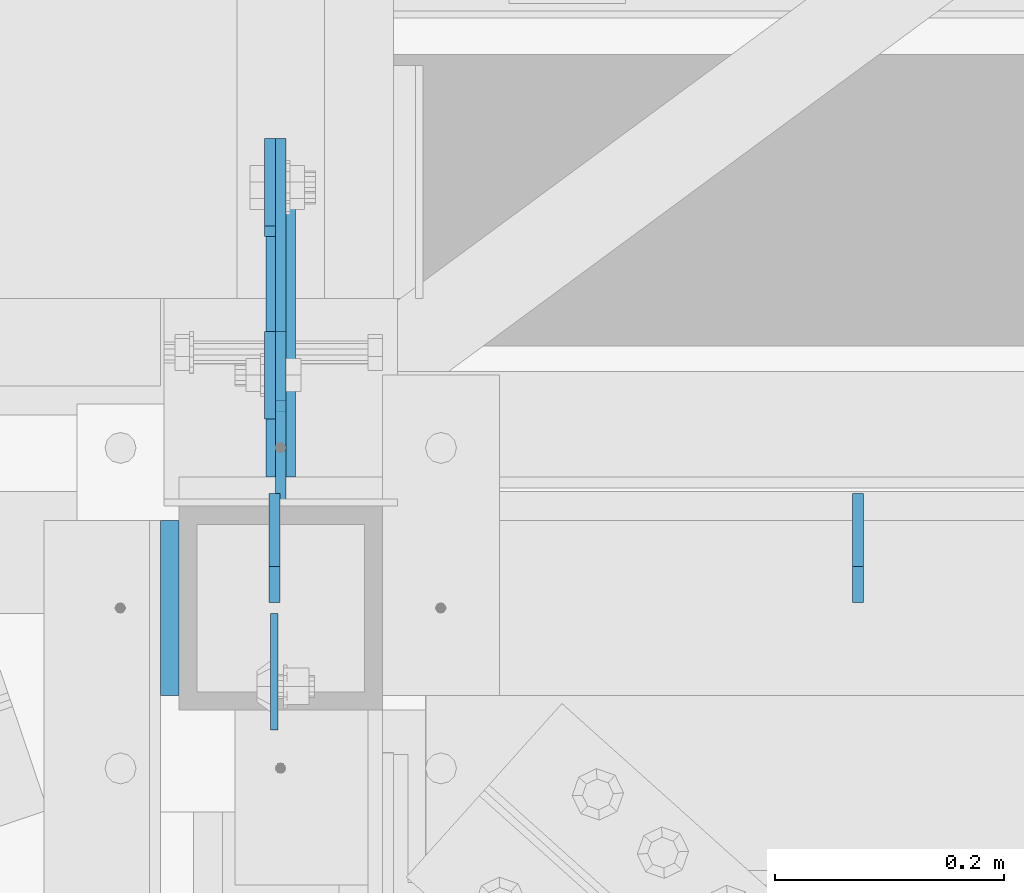
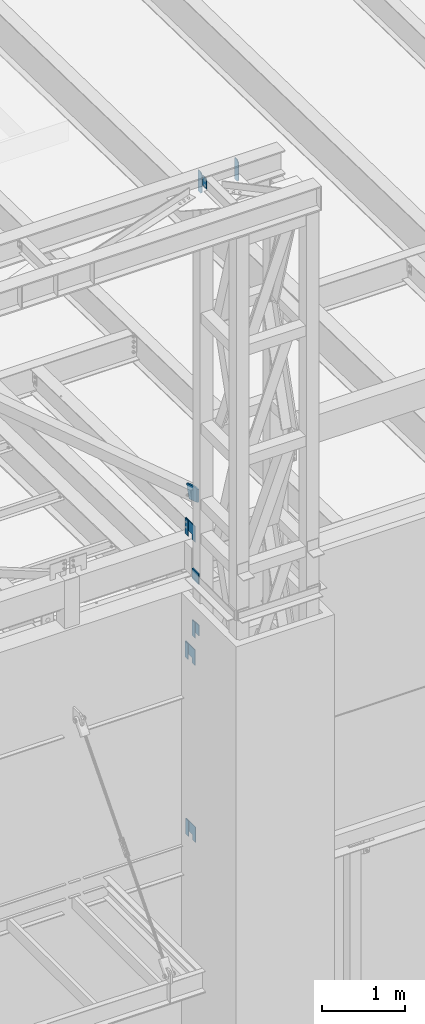
# One storey, part 1480 of 1763: 13 plates, 6 elements without a shape of their own.
"""IFC2X3 building model written with IfcOpenShell, lengths in millimetres."""

from ifc_helpers import new_model, si_unit, frame, origin_with_axes, place, context, subcontext, project, spatial, faceted_brep, material, type_object, element, aggregate, save


model = new_model("IFC2X3")

# Units and contexts
model_context = context("Model", 3, precision=1e-05, world=origin_with_axes())
body_context = subcontext(model_context, "Body", "Model", "MODEL_VIEW")
ifc_project = project(units=[si_unit("LENGTHUNIT", "METRE", prefix="MILLI"), si_unit("AREAUNIT", "SQUARE_METRE"), si_unit("VOLUMEUNIT", "CUBIC_METRE"), si_unit("MASSUNIT", "GRAM", prefix="KILO"), si_unit("TIMEUNIT", "SECOND"), si_unit("PLANEANGLEUNIT", "RADIAN"), si_unit("SOLIDANGLEUNIT", "STERADIAN"), si_unit("THERMODYNAMICTEMPERATUREUNIT", "DEGREE_CELSIUS"), si_unit("LUMINOUSINTENSITYUNIT", "LUMEN")], contexts=[model_context])

# Site, building, storey
site_placement = place(None, origin_with_axes())
site = spatial("IfcSite", under=ifc_project, at=site_placement, CompositionType="ELEMENT")
building_placement = place(site_placement, origin_with_axes())
building = spatial("IfcBuilding", under=site, at=building_placement, Name="Undefined", CompositionType="ELEMENT")
storey_placement = place(building_placement, origin_with_axes())
storey = spatial("IfcBuildingStorey", under=building, at=storey_placement, Name="Undefined", CompositionType="ELEMENT", Elevation=0.0)

# Assembly, plate
assembly_1_placement = place(storey_placement, origin_with_axes())
assembly_1 = element("IfcElementAssembly", 1, at=assembly_1_placement, inside=storey, Name="BEAM", AssemblyPlace="NOTDEFINED", PredefinedType="RIGID_FRAME")
ifc_material = material(Name="STEEL/A36")
plate_type_1 = type_object("IfcPlateType", PredefinedType="NOTDEFINED")
plate_1_placement = place(assembly_1_placement, frame((-47745.0773941528, -14179.5521887748, 8839.2), z_axis=(0.0, 0.0, 1.0), x_axis=(0.0, -1.0, 0.0)))
plate_1 = element("IfcPlate", 2, at=plate_1_placement, type_object=plate_type_1, material=ifc_material, Name="PLATE", context=body_context, shape_type="Brep", body=[
    faceted_brep([(0.0, -4.76249999999982, 0.0), (-2.83762346953154e-10, -4.7624999996915, 228.600006103516), (-2.83762346953154e-10, 4.76250000028813, 228.600006103517), (0.0, 4.76249999999982, 0.0), (76.1999969480166, -4.76249999961874, 228.600006103516), (76.1999969480166, 4.76250000036089, 228.600006103517), (76.1999969482931, -4.76249999991705, 0.0), (76.1999969482931, 4.76250000006257, 1.81898940354586e-12)], [[[0, 1, 2, 3]], [[1, 4, 5, 2]], [[4, 6, 7, 5]], [[6, 0, 3, 7]], [[5, 7, 3, 2]], [[6, 4, 1, 0]]]),
])
aggregate(assembly_1, [plate_1])

assembly_2_placement = place(storey_placement, origin_with_axes())
assembly_2 = element("IfcElementAssembly", 3, at=assembly_2_placement, inside=storey, Name="BEAM", AssemblyPlace="NOTDEFINED", PredefinedType="RIGID_FRAME")
plate_2_placement = place(assembly_2_placement, frame((-47745.0774000216, -14170.027189118, 11442.7), z_axis=(0.0, 0.0, 1.0), x_axis=(0.0, -1.0, 0.0)))
plate_2 = element("IfcPlate", 4, at=plate_2_placement, type_object=plate_type_1, material=ifc_material, Name="PLATE", context=body_context, shape_type="Brep", body=[
    faceted_brep([(0.0, -4.76249999999982, 0.0), (-2.83762346953154e-10, -4.7624999996915, 228.600006103516), (-2.83762346953154e-10, 4.76250000028813, 228.600006103517), (0.0, 4.76249999999982, 0.0), (76.1999969480166, -4.76249999961874, 228.600006103516), (76.1999969480166, 4.76250000036089, 228.600006103517), (76.1999969482931, -4.76249999991705, 0.0), (76.1999969482931, 4.76250000006257, 1.81898940354586e-12)], [[[0, 1, 2, 3]], [[1, 4, 5, 2]], [[4, 6, 7, 5]], [[6, 0, 3, 7]], [[5, 7, 3, 2]], [[6, 4, 1, 0]]]),
])
aggregate(assembly_2, [plate_2])

assembly_3_placement = place(storey_placement, origin_with_axes())
assembly_3 = element("IfcElementAssembly", 5, at=assembly_3_placement, inside=storey, Name="BEAM", AssemblyPlace="NOTDEFINED", PredefinedType="RIGID_FRAME")
plate_3_placement = place(assembly_3_placement, frame((-47745.0774016422, -14414.5021973342, 11858.625), z_axis=(0.0, 0.0, 1.0), x_axis=(0.0, 1.0, 0.0)))
plate_3 = element("IfcPlate", 6, at=plate_3_placement, type_object=plate_type_1, material=ifc_material, Name="PLATE", context=body_context, shape_type="Brep", body=[
    faceted_brep([(0.0, -4.76249999999982, 0.0), (-2.83762346953154e-10, -4.7624999996915, 228.600006103516), (-2.83762346953154e-10, 4.76250000028813, 228.600006103517), (0.0, 4.76249999999982, 0.0), (76.1999969480166, -4.76249999961874, 228.600006103516), (76.1999969480166, 4.76250000036089, 228.600006103517), (76.1999969482931, -4.76249999991705, 0.0), (76.1999969482931, 4.76250000006257, 1.81898940354586e-12)], [[[0, 1, 2, 3]], [[1, 4, 5, 2]], [[4, 6, 7, 5]], [[6, 0, 3, 7]], [[5, 7, 3, 2]], [[6, 4, 1, 0]]]),
])
aggregate(assembly_3, [plate_3])

assembly_4_placement = place(storey_placement, origin_with_axes())
assembly_4 = element("IfcElementAssembly", 7, at=assembly_4_placement, inside=storey, Name="BEAM", AssemblyPlace="NOTDEFINED", PredefinedType="RIGID_FRAME")
plate_4_placement = place(assembly_4_placement, frame((-47745.0774018501, -14170.0271890037, 13258.8221257957), z_axis=(0.0, 0.0, 1.0), x_axis=(0.0, -1.0, 0.0)))
plate_4 = element("IfcPlate", 8, at=plate_4_placement, type_object=plate_type_1, material=ifc_material, Name="PLATE", context=body_context, shape_type="Brep", body=[
    faceted_brep([(0.0, -4.76249999999982, 0.0), (-2.83762346953154e-10, -4.7624999996915, 228.600006103516), (-2.83762346953154e-10, 4.76250000028813, 228.600006103517), (0.0, 4.76249999999982, 0.0), (76.1999969480166, -4.76249999961874, 228.600006103516), (76.1999969480166, 4.76250000036089, 228.600006103517), (76.1999969482931, -4.76249999991705, 0.0), (76.1999969482931, 4.76250000006257, 1.81898940354586e-12)], [[[0, 1, 2, 3]], [[1, 4, 5, 2]], [[4, 6, 7, 5]], [[6, 0, 3, 7]], [[5, 7, 3, 2]], [[6, 4, 1, 0]]]),
])
aggregate(assembly_4, [plate_4])

# Assembly, plates
assembly_5_placement = place(storey_placement, origin_with_axes())
assembly_5 = element("IfcElementAssembly", 9, at=assembly_5_placement, inside=storey, Name="FRAME", AssemblyPlace="NOTDEFINED", PredefinedType="RIGID_FRAME")
plate_type_2 = type_object("IfcPlateType", PredefinedType="NOTDEFINED")
plate_5_placement = place(assembly_5_placement, frame((-47735.5523971252, -14408.1595639567, 9067.75577032242), z_axis=(-4.00000135414302e-09, 9.67160000327568e-05, -0.999999995323008), x_axis=(-1.2000009728941e-08, 0.999999995323008, 9.67160000319667e-05)))
plate_5 = element("IfcPlate", 10, at=plate_5_placement, type_object=plate_type_2, material=ifc_material, Name="PLATE", context=body_context, shape_type="Brep", body=[
    faceted_brep([(0.0, -4.76249999999982, 0.0), (-0.0147415312894736, -4.76250000055734, 228.577880859459), (-0.0147415312967496, 4.76249999946594, 228.577880859457), (0.0, 4.76249999999982, 0.0), (76.1926269535688, -4.76250000031723, 228.563140869262), (76.1926269535616, 4.76249999970605, 228.563140869261), (76.1999969485987, -4.76250000013533, 152.385253906345), (76.1999969485914, 4.76249999988795, 152.385253906343), (228.59263610909, -4.76249999964057, 152.399993896655), (228.592636109082, 4.76250000037544, 152.399993896655), (228.607376099128, -4.76249999928405, 2.14640749618411e-10), (228.607376099135, 4.76250000073924, 2.12821760214865e-10)], [[[0, 1, 2, 3]], [[1, 4, 5, 2]], [[4, 6, 7, 5]], [[6, 8, 9, 7]], [[8, 10, 11, 9]], [[10, 0, 3, 11]], [[5, 7, 9, 11, 3, 2]], [[10, 8, 6, 4, 1, 0]]]),
])
plate_6_placement = place(assembly_5_placement, frame((-47735.5523971252, -14398.6345639567, 11671.2557703224), z_axis=(-4.00000135414302e-09, 9.67160000327568e-05, -0.999999995323008), x_axis=(-1.2000009728941e-08, 0.999999995323008, 9.67160000319667e-05)))
plate_6 = element("IfcPlate", 11, at=plate_6_placement, type_object=plate_type_2, material=ifc_material, Name="PLATE", context=body_context, shape_type="Brep", body=[
    faceted_brep([(0.0, -4.76249999999982, 0.0), (-0.0147415312894736, -4.76250000055734, 228.577880859459), (-0.0147415312967496, 4.76249999946594, 228.577880859457), (0.0, 4.76249999999982, 0.0), (76.1926269535688, -4.76250000031723, 228.563140869262), (76.1926269535616, 4.76249999970605, 228.563140869261), (76.1999969485987, -4.76250000013533, 152.385253906345), (76.1999969485914, 4.76249999988795, 152.385253906343), (228.59263610909, -4.76249999964057, 152.399993896655), (228.592636109082, 4.76250000037544, 152.399993896655), (228.607376099128, -4.76249999928405, 2.14640749618411e-10), (228.607376099135, 4.76250000073924, 2.12821760214865e-10)], [[[0, 1, 2, 3]], [[1, 4, 5, 2]], [[4, 6, 7, 5]], [[6, 8, 9, 7]], [[8, 10, 11, 9]], [[10, 0, 3, 11]], [[5, 7, 9, 11, 3, 2]], [[10, 8, 6, 4, 1, 0]]]),
])
plate_7_placement = place(assembly_5_placement, frame((-47735.5523993351, -14398.6345639567, 13487.3778961182), z_axis=(-4.00000135414302e-09, 9.67160000327568e-05, -0.999999995323008), x_axis=(-1.2000009728941e-08, 0.999999995323008, 9.67160000319667e-05)))
plate_7 = element("IfcPlate", 12, at=plate_7_placement, type_object=plate_type_2, material=ifc_material, Name="PLATE", context=body_context, shape_type="Brep", body=[
    faceted_brep([(0.0, -4.76249999999982, 0.0), (-0.0147415312894736, -4.76250000055734, 228.577880859459), (-0.0147415312967496, 4.76249999946594, 228.577880859457), (0.0, 4.76249999999982, 0.0), (76.1926269535688, -4.76250000031723, 228.563140869262), (76.1926269535616, 4.76249999970605, 228.563140869261), (76.1999969485987, -4.76250000013533, 152.385253906345), (76.1999969485914, 4.76249999988795, 152.385253906343), (228.59263610909, -4.76249999964057, 152.399993896655), (228.592636109082, 4.76250000037544, 152.399993896655), (228.607376099128, -4.76249999928405, 2.14640749618411e-10), (228.607376099135, 4.76250000073924, 2.12821760214865e-10)], [[[0, 1, 2, 3]], [[1, 4, 5, 2]], [[4, 6, 7, 5]], [[6, 8, 9, 7]], [[8, 10, 11, 9]], [[10, 0, 3, 11]], [[5, 7, 9, 11, 3, 2]], [[10, 8, 6, 4, 1, 0]]]),
])
plate_type_3 = type_object("IfcPlateType", PredefinedType="NOTDEFINED")
plate_8_placement = place(assembly_5_placement, frame((-47735.5524031422, -14338.3022003384, 12087.2250061035), z_axis=(0.0, 0.0, -1.0), x_axis=(0.0, -1.0, 0.0)))
plate_8 = element("IfcPlate", 13, at=plate_8_placement, type_object=plate_type_3, material=ifc_material, Name="PLATE", context=body_context, shape_type="Brep", body=[
    faceted_brep([(0.0, -4.76249999999982, 0.0), (-3.05175672110636e-06, -4.7625000002663, 152.399993896484), (-3.05175490211695e-06, 4.76249999972788, 152.399993896484), (0.0, 4.76249999999982, 0.0), (152.400009155272, -4.76249999975698, 152.399993896484), (152.400009155273, 4.76250000024447, 152.399993896484), (152.400009155272, -4.76249999948777, 5.45696821063757e-12), (152.400009155273, 4.76250000051368, 3.63797880709171e-12)], [[[0, 1, 2, 3]], [[1, 4, 5, 2]], [[4, 6, 7, 5]], [[6, 0, 3, 7]], [[5, 7, 3, 2]], [[6, 4, 1, 0]]]),
])
plate_type_4 = type_object("IfcPlateType", PredefinedType="NOTDEFINED")
plate_9_placement = place(assembly_5_placement, frame((-47735.5634959181, -14465.3023149687, 14078.6557910015), z_axis=(0.0, 0.0, -1.0), x_axis=(0.0, 1.0, 0.0)))
plate_9 = element("IfcPlate", 14, at=plate_9_placement, type_object=plate_type_4, material=ifc_material, Name="PLATE", context=body_context, shape_type="Brep", body=[
    faceted_brep([(0.0, -12.6999999999971, -1.81898940354586e-12), (3.61378624802455e-08, -12.6999999999971, 191.819641113281), (3.61378624802455e-08, 12.6999999999971, 191.819641113281), (0.0, 12.6999999999971, -1.81898940354586e-12), (198.309204101633, -12.6999999999971, 255.740051269475), (198.309204101633, 12.6999999999971, 255.740051269475), (260.647735595721, -12.6999999999971, 62.3385391234624), (260.647735595721, 12.6999999999971, 62.3385391234624), (67.246223449707, -12.6999999999971, -2.36468622460961e-11), (67.246223449707, 12.6999999999971, -2.36468622460961e-11)], [[[0, 1, 2, 3]], [[1, 4, 5, 2]], [[4, 6, 7, 5]], [[6, 8, 9, 7]], [[8, 0, 3, 9]], [[5, 7, 9, 3, 2]], [[8, 6, 4, 1, 0]]]),
])

assembly_6_placement = place(storey_placement, origin_with_axes())
assembly_6 = element("IfcElementAssembly", 15, at=assembly_6_placement, inside=storey, Name="BEAM", AssemblyPlace="NOTDEFINED", PredefinedType="RIGID_FRAME")
plate_type_5 = type_object("IfcPlateType", PredefinedType="NOTDEFINED")
plate_10_placement = place(assembly_6_placement, frame((-47741.1086440791, -14584.3648088076, 18783.3), z_axis=(0.0, -1.0, 0.0), x_axis=(0.0, 0.0, -1.0)))
plate_10 = element("IfcPlate", 16, at=plate_10_placement, type_object=plate_type_5, material=ifc_material, Name="PLATE", context=body_context, shape_type="Brep", body=[
    faceted_brep([(1.81898940354586e-12, -3.17500000000291, 0.0), (0.0, -3.17499999999927, 101.599998474121), (0.0, 3.17499999999927, 101.599998474121), (-1.81898940354586e-12, 3.17499999997381, 0.0), (152.399993896484, -3.17499999999927, 101.599998474121), (152.399993896484, 3.17499999999927, 101.599998474121), (152.399993896484, -3.17500000000291, 0.0), (152.399993896484, 3.17500000000291, 0.0)], [[[0, 1, 2, 3]], [[1, 4, 5, 2]], [[4, 6, 7, 5]], [[6, 0, 3, 7]], [[5, 7, 3, 2]], [[6, 4, 1, 0]]]),
])
plate_type_6 = type_object("IfcPlateType", PredefinedType="NOTDEFINED")
plate_11_placement = place(assembly_6_placement, frame((-47232.3149124045, -14574.839811816, 18488.025), z_axis=(0.0, 0.0, 1.0), x_axis=(0.0, 1.0, 0.0)))
plate_11 = element("IfcPlate", 17, at=plate_11_placement, type_object=plate_type_6, material=ifc_material, Name="PLATE", context=body_context, shape_type="Brep", body=[
    faceted_brep([(0.0, -4.76250000000073, 31.75), (-3.63797880709171e-12, -4.76249999999709, 282.575012207031), (3.63797880709171e-12, 4.76249999999709, 282.575012207031), (0.0, 4.76250000000073, 31.75), (31.7499999999964, -4.7625000000844, 314.325012207031), (31.7500000000036, 4.76249999991705, 314.325012207031), (95.2499999999964, -4.76250000025902, 314.325012207031), (95.2500000000036, 4.76249999974243, 314.325012207031), (95.2499999999964, -4.76250000025902, 0.0), (95.2500000000036, 4.76249999974243, 0.0), (31.75, -4.76250000000073, 0.0), (31.75, 4.76250000000073, 0.0)], [[[0, 1, 2, 3]], [[1, 4, 5, 2]], [[4, 6, 7, 5]], [[6, 8, 9, 7]], [[8, 10, 11, 9]], [[10, 0, 3, 11]], [[5, 7, 9, 11, 3, 2]], [[10, 8, 6, 4, 1, 0]]]),
])
plate_12_placement = place(assembly_6_placement, frame((-47741.1086440219, -14574.8398087632, 18488.025), z_axis=(0.0, 0.0, 1.0), x_axis=(0.0, 1.0, 0.0)))
plate_12 = element("IfcPlate", 18, at=plate_12_placement, type_object=plate_type_6, material=ifc_material, Name="PLATE", context=body_context, shape_type="Brep", body=[
    faceted_brep([(0.0, -4.76250000000073, 31.75), (-3.63797880709171e-12, -4.76249999999709, 282.575012207031), (3.63797880709171e-12, 4.76249999999709, 282.575012207031), (0.0, 4.76250000000073, 31.75), (31.7499999999964, -4.7625000000844, 314.325012207031), (31.7500000000036, 4.76249999991705, 314.325012207031), (95.2499999999964, -4.76250000025902, 314.325012207031), (95.2500000000036, 4.76249999974243, 314.325012207031), (95.2499999999964, -4.76250000025902, 0.0), (95.2500000000036, 4.76249999974243, 0.0), (31.75, -4.76250000000073, 0.0), (31.75, 4.76250000000073, 0.0)], [[[0, 1, 2, 3]], [[1, 4, 5, 2]], [[4, 6, 7, 5]], [[6, 8, 9, 7]], [[8, 10, 11, 9]], [[10, 0, 3, 11]], [[5, 7, 9, 11, 3, 2]], [[10, 8, 6, 4, 1, 0]]]),
])
aggregate(assembly_6, [plate_11, plate_12, plate_10])

# Plate
plate_type_7 = type_object("IfcPlateType", PredefinedType="NOTDEFINED")
plate_13_placement = place(assembly_5_placement, frame((-47832.3898997267, -14655.8022094127, 12979.3999938965), z_axis=(0.0, 0.0, -1.0), x_axis=(0.0, 1.0, 0.0)))
plate_13 = element("IfcPlate", 19, at=plate_13_placement, type_object=plate_type_7, material=ifc_material, Name="PLATE", context=body_context, shape_type="Brep", body=[
    faceted_brep([(-7.27595761418343e-12, -7.9375, 0.0), (7.27595761418343e-12, -7.9375, 152.399993896484), (7.27595761418343e-12, 7.9375, 152.399993896484), (-7.27595761418343e-12, 7.9375, 0.0), (152.399993896484, -7.9375, 152.399993896484), (152.399993896484, 7.9375, 152.399993896484), (152.399993896484, -7.9375, -1.81898940354586e-12), (152.399993896484, 7.9375, -1.81898940354586e-12)], [[[0, 1, 2, 3]], [[1, 4, 5, 2]], [[4, 6, 7, 5]], [[6, 0, 3, 7]], [[5, 7, 3, 2]], [[6, 4, 1, 0]]]),
])

aggregate(assembly_5, [plate_9, plate_13, plate_5, plate_6, plate_8, plate_7])

save(model, "model.ifc")
